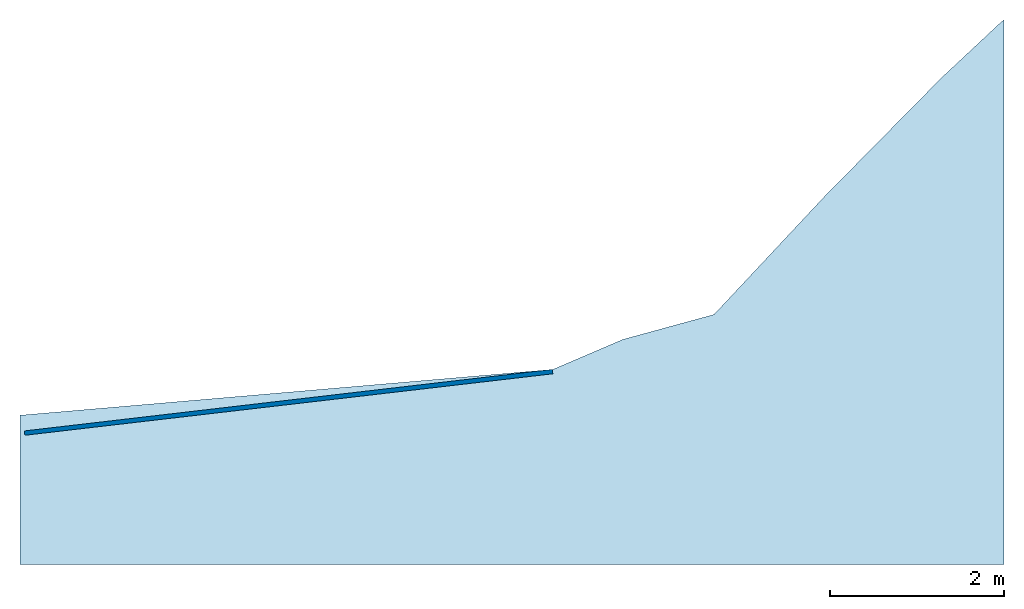
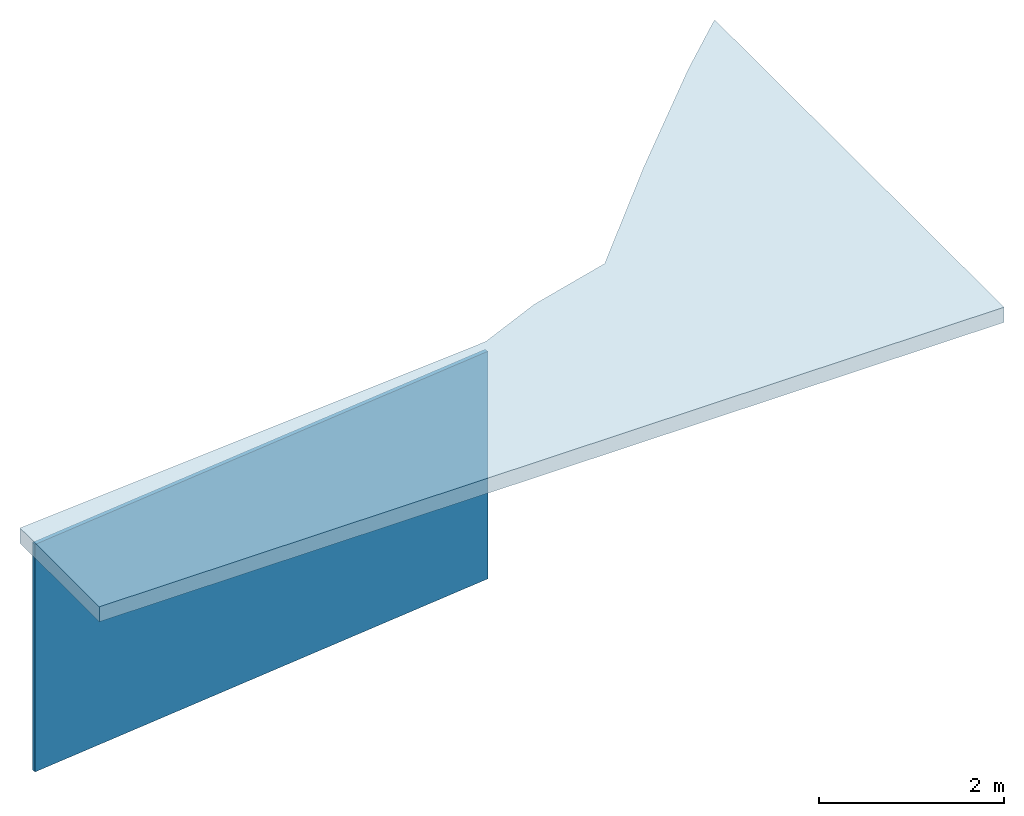
# Not in any storey: 1 slab, 1 wall.
"""IFC4 model written with IfcOpenShell, lengths in metres."""

import ifcopenshell
import ifcopenshell.guid

model = None  # the IFC model being written
_history = None  # IfcOwnerHistory: only IFC2X3 demands one
_inside = {}  # id of a spatial element -> (the spatial element, [elements in it])
_under = {}  # id of a project, library or spatial element -> (it, [spatial elements below it])
_declared = {}  # id of a project -> (the project, [libraries it declares])
_typed = {}  # id of a type object -> (the type object, [elements of that type])
_made_of = {}  # id of a material, layer set ... -> (it, [elements and type objects made of it])


def new_model(schema):
    """Start an empty IFC model of exactly this schema.

    Asked for "IFC4X3", IfcOpenShell would pick the latest addendum, in which some entities
    have other attributes; the version numbers below select the first issue.
    IFC2X3 requires an IfcOwnerHistory on every rooted entity: one is made here for all.
    """
    global model, _history
    if schema == "IFC4X3":
        model = ifcopenshell.file(schema_version=(4, 3, 0, 0))
    else:
        model = ifcopenshell.file(schema=schema)
    _inside.clear()
    _under.clear()
    _declared.clear()
    _typed.clear()
    _made_of.clear()
    _history = None
    if model.schema == "IFC2X3":
        org = make("IfcOrganization", Name="unknown")
        user = make(
            "IfcPersonAndOrganization",
            ThePerson=make("IfcPerson", FamilyName="unknown"),
            TheOrganization=org,
        )
        app = make(
            "IfcApplication",
            ApplicationDeveloper=org,
            Version="unknown",
            ApplicationFullName="unknown",
            ApplicationIdentifier="unknown",
        )
        _history = make(
            "IfcOwnerHistory",
            OwningUser=user,
            OwningApplication=app,
            ChangeAction="ADDED",
            CreationDate=0,
        )
    return model


def make(cls, **values):
    """One entity of the class cls with the attributes given. An attribute that is None is left unset."""
    return model.create_entity(
        cls, **{name: value for name, value in values.items() if value is not None}
    )


def entity(cls, *values):
    """Any entity or typed value of the class cls, its attributes in the order of the schema. None: left unset."""
    e = model.create_entity(cls)
    for i, value in enumerate(values):
        if value is not None:
            e[i] = value
    return e


def rooted(cls, **values):
    """An entity with a GlobalId (a new one), such as an element, a storey or a relation."""
    return make(cls, GlobalId=ifcopenshell.guid.new(), OwnerHistory=_history, **values)


def si_unit(unit_type, name, prefix=None):
    """IfcSIUnit, for example si_unit("LENGTHUNIT", "METRE", prefix="MILLI")."""
    return make("IfcSIUnit", UnitType=unit_type, Prefix=prefix, Name=name)


def converted_unit(unit_type, name, factor, base, dimensions=None, offset=None):
    """IfcConversionBasedUnit, such as the inch: factor (a typed value) times the base unit."""
    return make(
        "IfcConversionBasedUnit"
        if offset is None
        else "IfcConversionBasedUnitWithOffset",
        ConversionOffset=offset,
        Dimensions=None
        if dimensions is None
        else entity("IfcDimensionalExponents", *dimensions),
        UnitType=unit_type,
        Name=name,
        ConversionFactor=make(
            "IfcMeasureWithUnit", ValueComponent=factor, UnitComponent=base
        ),
    )


def assignment(units):
    """IfcUnitAssignment: the units of a project."""
    return None if units is None else make("IfcUnitAssignment", Units=units)


def point(xyz):
    """IfcCartesianPoint."""
    return None if xyz is None else make("IfcCartesianPoint", Coordinates=xyz)


def direction(xyz):
    """IfcDirection."""
    return None if xyz is None else make("IfcDirection", DirectionRatios=xyz)


def frame(location, z_axis=None, x_axis=None):
    """IfcAxis2Placement3D, a coordinate frame: its origin and axes. An axis left out is left unset."""
    return make(
        "IfcAxis2Placement3D",
        Location=point(location),
        Axis=direction(z_axis),
        RefDirection=direction(x_axis),
    )


def frame_2d(location, x_axis=None):
    """IfcAxis2Placement2D, a coordinate frame in the plane: its origin and x axis."""
    return make(
        "IfcAxis2Placement2D", Location=point(location), RefDirection=direction(x_axis)
    )


def origin_with_axes():
    """The frame at (0, 0, 0) with the z axis (0, 0, 1) and the x axis (1, 0, 0) written out."""
    return frame((0.0, 0.0, 0.0), z_axis=(0.0, 0.0, 1.0), x_axis=(1.0, 0.0, 0.0))


def origin_2d_with_axis():
    """The frame at (0, 0) in the plane with the x axis (1, 0) written out."""
    return frame_2d((0.0, 0.0), x_axis=(1.0, 0.0))


def place(relative_to, where):
    """IfcLocalPlacement: puts the frame where relative to a parent placement (None: the world)."""
    return make(
        "IfcLocalPlacement", PlacementRelTo=relative_to, RelativePlacement=where
    )


def context(
    kind, dimensions, precision=None, world=None, true_north=None, identifier=None
):
    """IfcGeometricRepresentationContext, for example the 3D "Model" context."""
    return make(
        "IfcGeometricRepresentationContext",
        ContextIdentifier=identifier,
        ContextType=kind,
        CoordinateSpaceDimension=dimensions,
        Precision=precision,
        WorldCoordinateSystem=world,
        TrueNorth=true_north,
    )


def subcontext(parent, identifier, kind, view, scale=None):
    """IfcGeometricRepresentationSubContext, for example "Body" below "Model"."""
    return make(
        "IfcGeometricRepresentationSubContext",
        ContextIdentifier=identifier,
        ContextType=kind,
        ParentContext=parent,
        TargetScale=scale,
        TargetView=view,
    )


def project(units=None, contexts=None):
    """IfcProject with its units and contexts."""
    return rooted(
        "IfcProject",
        Name="project",
        RepresentationContexts=contexts,
        UnitsInContext=assignment(units),
    )


def point_list(points):
    """IfcCartesianPointList2D or 3D."""
    cls = (
        "IfcCartesianPointList2D" if len(points[0]) == 2 else "IfcCartesianPointList3D"
    )
    return make(cls, CoordList=points)


def indexed_curve(points, segments=None, self_intersect=None):
    """IfcIndexedPolyCurve: lines and arcs through numbered points (the first is 1)."""
    return make(
        "IfcIndexedPolyCurve",
        Points=point_list(points),
        Segments=segments,
        SelfIntersect=self_intersect,
    )


def outline(outer, holes=None, kind="AREA"):
    """IfcArbitraryClosedProfileDef: a profile drawn as a closed curve; with holes, ...WithVoids."""
    if holes is None:
        return make("IfcArbitraryClosedProfileDef", ProfileType=kind, OuterCurve=outer)
    return make(
        "IfcArbitraryProfileDefWithVoids",
        ProfileType=kind,
        OuterCurve=outer,
        InnerCurves=holes,
    )


def extrude(swept, where, along, depth):
    """IfcExtrudedAreaSolid: the profile swept, set in the frame where, extruded along a direction by depth."""
    return make(
        "IfcExtrudedAreaSolid",
        SweptArea=swept,
        Position=where,
        ExtrudedDirection=direction(along),
        Depth=depth,
    )


def shape(context_of_items, identifier, shape_type, items):
    """IfcShapeRepresentation: the items that make up one representation, for example the "Body"."""
    return make(
        "IfcShapeRepresentation",
        ContextOfItems=context_of_items,
        RepresentationIdentifier=identifier,
        RepresentationType=shape_type,
        Items=items,
    )


def material(Name=None, Category=None):
    """IfcMaterial."""
    return make("IfcMaterial", Name=Name, Category=Category)


def layer(
    of_material, thickness, ventilated=None, Name=None, Category=None, Priority=None
):
    """IfcMaterialLayer: one layer of a wall or slab, of a material (None: an air gap)."""
    return make(
        "IfcMaterialLayer",
        Material=of_material,
        LayerThickness=thickness,
        IsVentilated=ventilated,
        Name=Name,
        Category=Category,
        Priority=Priority,
    )


def layer_set(layers, Name=None):
    """IfcMaterialLayerSet."""
    return make("IfcMaterialLayerSet", MaterialLayers=layers, LayerSetName=Name)


def layer_usage(for_layer_set, set_direction, sense, offset, extent=None):
    """IfcMaterialLayerSetUsage: how a layer set lies in its element."""
    return make(
        "IfcMaterialLayerSetUsage",
        ForLayerSet=for_layer_set,
        LayerSetDirection=set_direction,
        DirectionSense=sense,
        OffsetFromReferenceLine=offset,
        ReferenceExtent=extent,
    )


def made_of(thing, what):
    """Note that an element or type object is made of a material, layer set ...; save() writes the relation."""
    if what is not None:
        _made_of.setdefault(what.id(), (what, []))[1].append(thing)
    return thing


def type_object(cls, material=None, **own):
    """A type object (cls), such as IfcWallType, which elements share."""
    return made_of(rooted(cls, **own), material)


def element(
    cls,
    number,
    at=None,
    inside=None,
    cuts=None,
    type_object=None,
    material=None,
    context=None,
    identifier="Body",
    shape_type=None,
    held_by="IfcProductDefinitionShape",
    body=None,
    shapes=None,
    **own,
):
    """One element of the class cls, such as IfcWall. Its Tag is "e" and its number.

    at: its placement. inside: the storey or other place that contains it. cuts: it is an
    opening in that element (IfcRelVoidsElement). A single representation is given by context,
    identifier, shape_type and body (its items); several are given by shapes. held_by: the class
    of the entity that holds the representations. save() writes the other relations.
    """
    e = rooted(cls, Tag="e%d" % number, ObjectPlacement=at, **own)
    if body is not None:
        shapes = [shape(context, identifier, shape_type, body)]
    if shapes is not None:
        e.Representation = make(held_by, Representations=shapes)
    if inside is not None:
        _inside.setdefault(inside.id(), (inside, []))[1].append(e)
    if cuts is not None:
        rooted(
            "IfcRelVoidsElement", RelatingBuildingElement=cuts, RelatedOpeningElement=e
        )
    if type_object is not None:
        _typed.setdefault(type_object.id(), (type_object, []))[1].append(e)
    return made_of(e, material)


def aggregate(whole, parts):
    """IfcRelAggregates: a whole, such as a stair, and the parts it consists of."""
    return rooted("IfcRelAggregates", RelatingObject=whole, RelatedObjects=parts)


def save(model, path):
    """Write the relations noted so far, then the file.

    IfcRelAggregates (storeys below a building ...), IfcRelContainedInSpatialStructure (elements
    in a storey), IfcRelDefinesByType, IfcRelAssociatesMaterial and IfcRelDeclares: one each for
    every whole, place, type object, material and project.
    """
    for whole, parts in _under.values():
        aggregate(whole, parts)
    for where, things in _inside.values():
        rooted(
            "IfcRelContainedInSpatialStructure",
            RelatedElements=things,
            RelatingStructure=where,
        )
    for kind, things in _typed.values():
        rooted("IfcRelDefinesByType", RelatedObjects=things, RelatingType=kind)
    for what, things in _made_of.values():
        rooted("IfcRelAssociatesMaterial", RelatedObjects=things, RelatingMaterial=what)
    for by, libraries in _declared.values():
        rooted("IfcRelDeclares", RelatingContext=by, RelatedDefinitions=libraries)
    model.write(path)


model = new_model("IFC4")

# Units and contexts
model_context = context("Model", 3, precision=1e-05, world=origin_with_axes())
plan_context = context("Plan", 2, precision=1e-05, world=origin_2d_with_axis())
body_context = subcontext(model_context, "Body", "Model", "MODEL_VIEW")
ifc_project = project(units=[si_unit("VOLUMEUNIT", "CUBIC_METRE"), si_unit("LENGTHUNIT", "METRE"), converted_unit("PLANEANGLEUNIT", "degree", entity("IfcReal", 0.0174532925199433), si_unit("PLANEANGLEUNIT", "RADIAN"), dimensions=[0, 0, 0, 0, 0, 0, 0]), si_unit("AREAUNIT", "SQUARE_METRE")], contexts=[model_context, plan_context])

# Slab
ifc_material = material()
ifc_layer_1 = layer(ifc_material, 0.2)
ifc_layer_set_1 = layer_set([ifc_layer_1])
ifc_layer_usage_1 = layer_usage(ifc_layer_set_1, "AXIS3", "POSITIVE", -0.200000002980232)
slab_type = type_object("IfcSlabType", Name="FLR200", PredefinedType="NOTDEFINED", material=ifc_layer_set_1)
placement_1 = place(None, origin_with_axes())
placement_2 = place(placement_1, origin_with_axes())
placement_3 = place(placement_2, origin_with_axes())
slab_placement = place(placement_3, frame((-3.42841506004333, -27.9065723419189, 3.09741735458374), z_axis=(0.0, 0.0, 1.0), x_axis=(1.0, 0.0, 0.0)))
element("IfcSlab", 1, at=slab_placement, type_object=slab_type, material=ifc_layer_usage_1, Name="Slab", context=body_context, shape_type="SweptSolid", body=[
    extrude(outline(indexed_curve([(6.11327075958252, 0.525897979736328), (6.91716289520264, 0.870632171630859), (7.95943069458008, 1.15534591674805), (9.23498725891113, 2.51817512512207), (10.569525718689, 3.87151336669922), (11.2467279434204, 4.50459480285645), (11.2849607467651, 4.53298377990723), (11.2849617004395, -1.71367073059082), (4.76837158203125e-07, -1.71367073059082), (0.0, 0.0), (6.11327075958252, 0.525897979736328)])), frame((0.0, 0.0, -0.200000002980232), z_axis=(0.0, 0.0, 1.0), x_axis=(1.0, 0.0, 0.0)), (0.0, 0.0, 1.0), 0.2),
])

# Wall
ifc_layer_2 = layer(ifc_material, 0.05)
ifc_layer_set_2 = layer_set([ifc_layer_2])
ifc_layer_usage_2 = layer_usage(ifc_layer_set_2, "AXIS2", "POSITIVE", 0.0)
placement_4 = place(placement_2, origin_with_axes())
wall_placement = place(placement_4, frame((2.67689847946167, -27.3813591003418, 0.0), z_axis=(0.0, 0.0, 1.0), x_axis=(-0.993290095235541, -0.115649412912345, 0.0)))
element("IfcWall", 2, at=wall_placement, material=ifc_layer_usage_2, Name="Wall", context=body_context, shape_type="SweptSolid", body=[
    extrude(outline(indexed_curve([(0.0, 0.0), (0.0, 0.05), (6.09621821815055, 0.05), (6.09621821815055, 0.0), (0.0, 0.0)], self_intersect=False)), origin_with_axes(), (0.0, 0.0, 1.0), 3.0),
])

save(model, "model.ifc")
